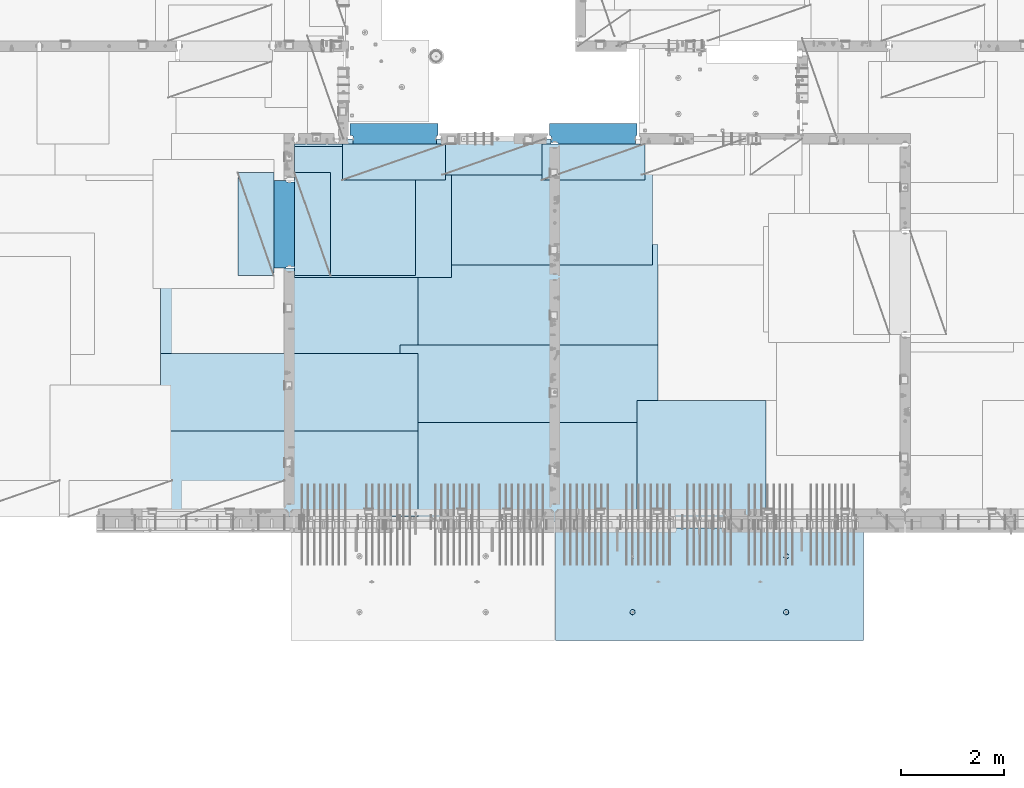
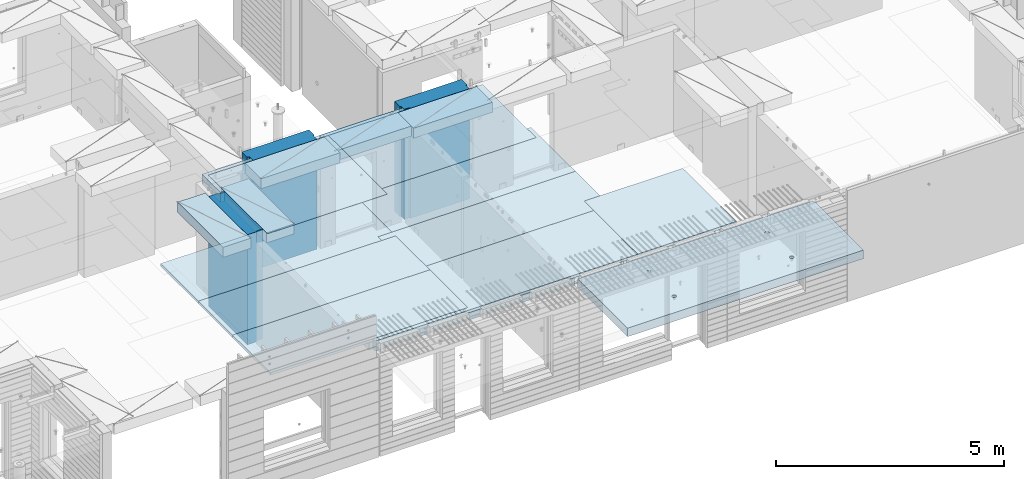
# One storey, part 174 of 309: 18 plates, 2 slabs, 19 elements without a shape of their own.
"""IFC2X3 building model written with IfcOpenShell, lengths in millimetres."""

from ifc_helpers import new_model, si_unit, frame, origin_with_axes, place, context, subcontext, project, spatial, faceted_brep, material, type_object, element, aggregate, save


model = new_model("IFC2X3")

# Units and contexts
model_context = context("Model", 3, precision=1e-05, world=origin_with_axes())
body_context = subcontext(model_context, "Body", "Model", "MODEL_VIEW")
ifc_project = project(units=[si_unit("LENGTHUNIT", "METRE", prefix="MILLI"), si_unit("AREAUNIT", "SQUARE_METRE"), si_unit("VOLUMEUNIT", "CUBIC_METRE"), si_unit("MASSUNIT", "GRAM", prefix="KILO"), si_unit("TIMEUNIT", "SECOND"), si_unit("PLANEANGLEUNIT", "RADIAN"), si_unit("SOLIDANGLEUNIT", "STERADIAN"), si_unit("THERMODYNAMICTEMPERATUREUNIT", "DEGREE_CELSIUS"), si_unit("LUMINOUSINTENSITYUNIT", "LUMEN")], contexts=[model_context])

# Site, building, storey
site_placement = place(None, origin_with_axes())
site = spatial("IfcSite", under=ifc_project, at=site_placement, CompositionType="ELEMENT")
building_placement = place(site_placement, origin_with_axes())
building = spatial("IfcBuilding", under=site, at=building_placement, CompositionType="ELEMENT")
storey_placement = place(building_placement, origin_with_axes())
storey = spatial("IfcBuildingStorey", under=building, at=storey_placement, Name="7", CompositionType="ELEMENT", Elevation=0.0)

# Assembly, plate
assembly_1_placement = place(storey_placement, origin_with_axes())
assembly_1 = element("IfcElementAssembly", 1, at=assembly_1_placement, inside=storey, Name="Steel Assembly", AssemblyPlace="NOTDEFINED", PredefinedType="NOTDEFINED")
ifc_material_1 = material()
plate_type_1 = type_object("IfcPlateType", PredefinedType="NOTDEFINED")
plate_1_placement = place(assembly_1_placement, frame((25910.0, 7750.0, 102695.1), z_axis=(-1.0, 3.00000001838171e-08, 0.0), x_axis=(0.0, 1.0, 0.0)))
plate_1 = element("IfcPlate", 2, at=plate_1_placement, type_object=plate_type_1, material=ifc_material_1, Name="1/2", context=body_context, shape_type="Brep", body=[
    faceted_brep([(0.0, -35.0, 0.0), (0.0, -35.0, 2500.0), (0.0, 35.0, 2500.0), (0.0, 35.0, 0.0), (2349.99951171875, -35.0, 2500.0), (2349.99951171875, 35.0, 2500.0), (2350.0, -35.0, 0.0), (2350.0, 35.0, 0.0)], [[[0, 1, 2, 3]], [[1, 4, 5, 2]], [[4, 6, 7, 5]], [[6, 0, 3, 7]], [[5, 7, 3, 2]], [[6, 4, 1, 0]]]),
])
aggregate(assembly_1, [plate_1])

assembly_2_placement = place(storey_placement, origin_with_axes())
assembly_2 = element("IfcElementAssembly", 3, at=assembly_2_placement, inside=storey, Name="Steel Assembly", AssemblyPlace="NOTDEFINED", PredefinedType="NOTDEFINED")
plate_2_placement = place(assembly_2_placement, frame((16759.9995320312, 12530.0000289158, 102695.1), z_axis=(0.0, 1.0, 0.0), x_axis=(1.0, 0.0, 0.0)))
plate_2 = element("IfcPlate", 4, at=plate_2_placement, type_object=plate_type_1, material=ifc_material_1, Name="1/2", context=body_context, shape_type="Brep", body=[
    faceted_brep([(0.0, -35.0, 0.0), (0.0, -35.0, 2500.0), (0.0, 35.0, 2500.0), (0.0, 35.0, 0.0), (2349.99951171875, -35.0, 2500.0), (2349.99951171875, 35.0, 2500.0), (2350.0, -35.0, 0.0), (2350.0, 35.0, 0.0)], [[[0, 1, 2, 3]], [[1, 4, 5, 2]], [[4, 6, 7, 5]], [[6, 0, 3, 7]], [[5, 7, 3, 2]], [[6, 4, 1, 0]]]),
])
aggregate(assembly_2, [plate_2])

assembly_3_placement = place(storey_placement, origin_with_axes())
assembly_3 = element("IfcElementAssembly", 5, at=assembly_3_placement, inside=storey, Name="Steel Assembly", AssemblyPlace="NOTDEFINED", PredefinedType="NOTDEFINED")
plate_3_placement = place(assembly_3_placement, frame((23810.0, 10780.0, 102695.1), z_axis=(-1.0, 3.00000001838171e-08, 0.0), x_axis=(0.0, 1.0, 0.0)))
plate_3 = element("IfcPlate", 6, at=plate_3_placement, type_object=plate_type_1, material=ifc_material_1, context=body_context, shape_type="Brep", body=[
    faceted_brep([(0.0, -35.0, 0.0), (0.0, -35.0, 5000.0), (0.0, 35.0, 5000.0), (0.0, 35.0, 0.0), (2349.99951171875, -35.0, 5000.0), (2349.99951171875, 35.0, 5000.0), (2350.0, -35.0, 0.0), (2350.0, 35.0, 0.0)], [[[0, 1, 2, 3]], [[1, 4, 5, 2]], [[4, 6, 7, 5]], [[6, 0, 3, 7]], [[5, 7, 3, 2]], [[6, 4, 1, 0]]]),
])
aggregate(assembly_3, [plate_3])

assembly_4_placement = place(storey_placement, origin_with_axes())
assembly_4 = element("IfcElementAssembly", 7, at=assembly_4_placement, inside=storey, Name="Steel Assembly", AssemblyPlace="NOTDEFINED", PredefinedType="NOTDEFINED")
plate_4_placement = place(assembly_4_placement, frame((23710.0, 12730.0, 102695.1), z_axis=(-1.0, 3.00000001838171e-08, 0.0), x_axis=(0.0, 1.0, 0.0)))
plate_4 = element("IfcPlate", 8, at=plate_4_placement, type_object=plate_type_1, material=ifc_material_1, context=body_context, shape_type="Brep", body=[
    faceted_brep([(0.0, -35.0, 0.0), (0.0, -35.0, 5000.0), (0.0, 35.0, 5000.0), (0.0, 35.0, 0.0), (2349.99951171875, -35.0, 5000.0), (2349.99951171875, 35.0, 5000.0), (2350.0, -35.0, 0.0), (2350.0, 35.0, 0.0)], [[[0, 1, 2, 3]], [[1, 4, 5, 2]], [[4, 6, 7, 5]], [[6, 0, 3, 7]], [[5, 7, 3, 2]], [[6, 4, 1, 0]]]),
])
aggregate(assembly_4, [plate_4])

assembly_5_placement = place(storey_placement, origin_with_axes())
assembly_5 = element("IfcElementAssembly", 9, at=assembly_5_placement, inside=storey, Name="Steel Assembly", AssemblyPlace="NOTDEFINED", PredefinedType="NOTDEFINED")
plate_5_placement = place(assembly_5_placement, frame((23810.0, 7750.0, 102695.1), z_axis=(-1.0, 3.00000001838171e-08, 0.0), x_axis=(0.0, 1.0, 0.0)))
plate_5 = element("IfcPlate", 10, at=plate_5_placement, type_object=plate_type_1, material=ifc_material_1, context=body_context, shape_type="Brep", body=[
    faceted_brep([(0.0, -35.0, 0.0), (0.0, -35.0, 5000.0), (0.0, 35.0, 5000.0), (0.0, 35.0, 0.0), (2349.99951171875, -35.0, 5000.0), (2349.99951171875, 35.0, 5000.0), (2350.0, -35.0, 0.0), (2350.0, 35.0, 0.0)], [[[0, 1, 2, 3]], [[1, 4, 5, 2]], [[4, 6, 7, 5]], [[6, 0, 3, 7]], [[5, 7, 3, 2]], [[6, 4, 1, 0]]]),
])
aggregate(assembly_5, [plate_5])

assembly_6_placement = place(storey_placement, origin_with_axes())
assembly_6 = element("IfcElementAssembly", 11, at=assembly_6_placement, inside=storey, Name="Steel Assembly", AssemblyPlace="NOTDEFINED", PredefinedType="NOTDEFINED")
plate_6_placement = place(assembly_6_placement, frame((19160.0, 10325.0, 102695.1), z_axis=(-1.0, 3.00000001838171e-08, 0.0), x_axis=(0.0, 1.0, 0.0)))
plate_6 = element("IfcPlate", 12, at=plate_6_placement, type_object=plate_type_1, material=ifc_material_1, context=body_context, shape_type="Brep", body=[
    faceted_brep([(0.0, -35.0, 0.0), (0.0, -35.0, 5000.0), (0.0, 35.0, 5000.0), (0.0, 35.0, 0.0), (2349.99951171875, -35.0, 5000.0), (2349.99951171875, 35.0, 5000.0), (2350.0, -35.0, 0.0), (2350.0, 35.0, 0.0)], [[[0, 1, 2, 3]], [[1, 4, 5, 2]], [[4, 6, 7, 5]], [[6, 0, 3, 7]], [[5, 7, 3, 2]], [[6, 4, 1, 0]]]),
])
aggregate(assembly_6, [plate_6])

assembly_7_placement = place(storey_placement, origin_with_axes())
assembly_7 = element("IfcElementAssembly", 13, at=assembly_7_placement, inside=storey, Name="Steel Assembly", AssemblyPlace="NOTDEFINED", PredefinedType="NOTDEFINED")
plate_7_placement = place(assembly_7_placement, frame((19160.0, 7850.0, 102695.1), z_axis=(-1.0, 3.00000001838171e-08, 0.0), x_axis=(0.0, 1.0, 0.0)))
plate_7 = element("IfcPlate", 14, at=plate_7_placement, type_object=plate_type_1, material=ifc_material_1, context=body_context, shape_type="Brep", body=[
    faceted_brep([(0.0, -35.0, 0.0), (0.0, -35.0, 5000.0), (0.0, 35.0, 5000.0), (0.0, 35.0, 0.0), (2349.99951171875, -35.0, 5000.0), (2349.99951171875, 35.0, 5000.0), (2350.0, -35.0, 0.0), (2350.0, 35.0, 0.0)], [[[0, 1, 2, 3]], [[1, 4, 5, 2]], [[4, 6, 7, 5]], [[6, 0, 3, 7]], [[5, 7, 3, 2]], [[6, 4, 1, 0]]]),
])
aggregate(assembly_7, [plate_7])

assembly_8_placement = place(storey_placement, origin_with_axes())
assembly_8 = element("IfcElementAssembly", 15, at=assembly_8_placement, inside=storey, Name="Steel Assembly", AssemblyPlace="NOTDEFINED", PredefinedType="NOTDEFINED")
plate_type_2 = type_object("IfcPlateType", PredefinedType="NOTDEFINED")
plate_8_placement = place(assembly_8_placement, frame((18810.0, 11180.0000122641, 102695.100000381), z_axis=(1.0, 0.0, 0.0), x_axis=(0.0, -1.0, 0.0)))
plate_8 = element("IfcPlate", 16, at=plate_8_placement, type_object=plate_type_2, material=ifc_material_1, context=body_context, shape_type="Brep", body=[
    faceted_brep([(0.0, -35.0, 0.0), (0.0, -35.0, 5000.0), (0.0, 35.0, 5000.0), (0.0, 35.0, 0.0), (1499.99951171875, -35.0, 5000.0), (1499.99951171875, 35.0, 5000.0), (1500.0, -35.0, 0.0), (1500.0, 35.0, 0.0)], [[[0, 1, 2, 3]], [[1, 4, 5, 2]], [[4, 6, 7, 5]], [[6, 0, 3, 7]], [[5, 7, 3, 2]], [[6, 4, 1, 0]]]),
])
aggregate(assembly_8, [plate_8])

assembly_9_placement = place(storey_placement, origin_with_axes())
assembly_9 = element("IfcElementAssembly", 17, at=assembly_9_placement, inside=storey, Name="Steel Assembly", AssemblyPlace="NOTDEFINED", PredefinedType="NOTDEFINED")
plate_9_placement = place(assembly_9_placement, frame((14160.0, 11015.0000122641, 102695.100000381), z_axis=(1.0, 0.0, 0.0), x_axis=(0.0, -1.0, 0.0)))
plate_9 = element("IfcPlate", 18, at=plate_9_placement, type_object=plate_type_2, material=ifc_material_1, context=body_context, shape_type="Brep", body=[
    faceted_brep([(0.0, -35.0, 0.0), (0.0, -35.0, 5000.0), (0.0, 35.0, 5000.0), (0.0, 35.0, 0.0), (1499.99951171875, -35.0, 5000.0), (1499.99951171875, 35.0, 5000.0), (1500.0, -35.0, 0.0), (1500.0, 35.0, 0.0)], [[[0, 1, 2, 3]], [[1, 4, 5, 2]], [[4, 6, 7, 5]], [[6, 0, 3, 7]], [[5, 7, 3, 2]], [[6, 4, 1, 0]]]),
])
aggregate(assembly_9, [plate_9])

assembly_10_placement = place(storey_placement, origin_with_axes())
assembly_10 = element("IfcElementAssembly", 19, at=assembly_10_placement, inside=storey, Name="Steel Assembly", AssemblyPlace="NOTDEFINED", PredefinedType="NOTDEFINED")
plate_type_3 = type_object("IfcPlateType", PredefinedType="NOTDEFINED")
plate_10_placement = place(assembly_10_placement, frame((16759.9998779297, 14525.0, 102595.3), z_axis=(1.0, 0.0, 0.0), x_axis=(0.0, -1.0, 0.0)))
plate_10 = element("IfcPlate", 20, at=plate_10_placement, type_object=plate_type_3, material=ifc_material_1, Name="RE1", context=body_context, shape_type="Brep", body=[
    faceted_brep([(1.81898940354586e-12, -135.0, 1.81898940354586e-12), (0.0, -135.0, 699.999999999996), (0.0, 135.0, 699.999999999996), (1.81898940354586e-12, 135.0, 1.81898940354586e-12), (1999.99951171875, -135.0, 699.999999999993), (1999.99951171875, 135.0, 699.999999999993), (2000.0, -135.0, -3.63797880709171e-12), (2000.0, 135.0, -3.63797880709171e-12)], [[[0, 1, 2, 3]], [[1, 4, 5, 2]], [[4, 6, 7, 5]], [[6, 0, 3, 7]], [[5, 7, 3, 2]], [[6, 4, 1, 0]]]),
])
aggregate(assembly_10, [plate_10])

assembly_11_placement = place(storey_placement, origin_with_axes())
assembly_11 = element("IfcElementAssembly", 21, at=assembly_11_placement, inside=storey, Name="Steel Assembly", AssemblyPlace="NOTDEFINED", PredefinedType="NOTDEFINED")
plate_11_placement = place(assembly_11_placement, frame((16359.7701220703, 12525.0, 102595.3), z_axis=(-1.0, 3.00000001838171e-08, 0.0), x_axis=(0.0, 1.0, 0.0)))
plate_11 = element("IfcPlate", 22, at=plate_11_placement, type_object=plate_type_3, material=ifc_material_1, Name="RE1", context=body_context, shape_type="Brep", body=[
    faceted_brep([(1.81898940354586e-12, -135.0, 1.81898940354586e-12), (0.0, -135.0, 699.999999999996), (0.0, 135.0, 699.999999999996), (1.81898940354586e-12, 135.0, 1.81898940354586e-12), (1999.99951171875, -135.0, 699.999999999993), (1999.99951171875, 135.0, 699.999999999993), (2000.0, -135.0, -3.63797880709171e-12), (2000.0, 135.0, -3.63797880709171e-12)], [[[0, 1, 2, 3]], [[1, 4, 5, 2]], [[4, 6, 7, 5]], [[6, 0, 3, 7]], [[5, 7, 3, 2]], [[6, 4, 1, 0]]]),
])
aggregate(assembly_11, [plate_11])

assembly_12_placement = place(storey_placement, origin_with_axes())
assembly_12 = element("IfcElementAssembly", 23, at=assembly_12_placement, inside=storey, Name="Steel Assembly", AssemblyPlace="NOTDEFINED", PredefinedType="NOTDEFINED")
plate_12_placement = place(assembly_12_placement, frame((21624.9991457614, 15179.9998963664, 102595.3), z_axis=(0.0, -1.0, 0.0), x_axis=(-1.0, 3.00000001838171e-08, 0.0)))
plate_12 = element("IfcPlate", 24, at=plate_12_placement, type_object=plate_type_3, material=ifc_material_1, Name="RE1", context=body_context, shape_type="Brep", body=[
    faceted_brep([(1.81898940354586e-12, -135.0, 1.81898940354586e-12), (0.0, -135.0, 699.999999999996), (0.0, 135.0, 699.999999999996), (1.81898940354586e-12, 135.0, 1.81898940354586e-12), (1999.99951171875, -135.0, 699.999999999993), (1999.99951171875, 135.0, 699.999999999993), (2000.0, -135.0, -3.63797880709171e-12), (2000.0, 135.0, -3.63797880709171e-12)], [[[0, 1, 2, 3]], [[1, 4, 5, 2]], [[4, 6, 7, 5]], [[6, 0, 3, 7]], [[5, 7, 3, 2]], [[6, 4, 1, 0]]]),
])
aggregate(assembly_12, [plate_12])

assembly_13_placement = place(storey_placement, origin_with_axes())
assembly_13 = element("IfcElementAssembly", 25, at=assembly_13_placement, inside=storey, Name="Steel Assembly", AssemblyPlace="NOTDEFINED", PredefinedType="NOTDEFINED")
plate_13_placement = place(assembly_13_placement, frame((23559.9991457614, 15079.9998963664, 102595.3), z_axis=(0.0, -1.0, 0.0), x_axis=(-1.0, 3.00000001838171e-08, 0.0)))
plate_13 = element("IfcPlate", 26, at=plate_13_placement, type_object=plate_type_3, material=ifc_material_1, Name="RE1", context=body_context, shape_type="Brep", body=[
    faceted_brep([(1.81898940354586e-12, -135.0, 1.81898940354586e-12), (0.0, -135.0, 699.999999999996), (0.0, 135.0, 699.999999999996), (1.81898940354586e-12, 135.0, 1.81898940354586e-12), (1999.99951171875, -135.0, 699.999999999993), (1999.99951171875, 135.0, 699.999999999993), (2000.0, -135.0, -3.63797880709171e-12), (2000.0, 135.0, -3.63797880709171e-12)], [[[0, 1, 2, 3]], [[1, 4, 5, 2]], [[4, 6, 7, 5]], [[6, 0, 3, 7]], [[5, 7, 3, 2]], [[6, 4, 1, 0]]]),
])
aggregate(assembly_13, [plate_13])

assembly_14_placement = place(storey_placement, origin_with_axes())
assembly_14 = element("IfcElementAssembly", 27, at=assembly_14_placement, inside=storey, Name="Steel Assembly", AssemblyPlace="NOTDEFINED", PredefinedType="NOTDEFINED")
plate_14_placement = place(assembly_14_placement, frame((19689.9991457614, 15079.9998963664, 102595.3), z_axis=(0.0, -1.0, 0.0), x_axis=(-1.0, 3.00000001838171e-08, 0.0)))
plate_14 = element("IfcPlate", 28, at=plate_14_placement, type_object=plate_type_3, material=ifc_material_1, Name="RE1", context=body_context, shape_type="Brep", body=[
    faceted_brep([(1.81898940354586e-12, -135.0, 1.81898940354586e-12), (0.0, -135.0, 699.999999999996), (0.0, 135.0, 699.999999999996), (1.81898940354586e-12, 135.0, 1.81898940354586e-12), (1999.99951171875, -135.0, 699.999999999993), (1999.99951171875, 135.0, 699.999999999993), (2000.0, -135.0, -3.63797880709171e-12), (2000.0, 135.0, -3.63797880709171e-12)], [[[0, 1, 2, 3]], [[1, 4, 5, 2]], [[4, 6, 7, 5]], [[6, 0, 3, 7]], [[5, 7, 3, 2]], [[6, 4, 1, 0]]]),
])
aggregate(assembly_14, [plate_14])

# Assembly, plate, slab
assembly_15_placement = place(storey_placement, origin_with_axes())
assembly_15 = element("IfcElementAssembly", 29, at=assembly_15_placement, inside=storey, AssemblyPlace="NOTDEFINED", PredefinedType="REINFORCEMENT_UNIT")
plate_type_4 = type_object("IfcPlateType", PredefinedType="NOTDEFINED")
plate_15_placement = place(assembly_15_placement, frame((16760.0002457424, 12487.9997681111, 102725.45), z_axis=(0.0, 1.0, 0.0), x_axis=(1.0, 0.0, 0.0)))
plate_15 = element("IfcPlate", 30, at=plate_15_placement, type_object=plate_type_4, material=ifc_material_1, context=body_context, shape_type="Brep", body=[
    faceted_brep([(0.0, -5.0, 0.0), (0.0, -5.0, 2592.0), (0.0, 5.0, 2592.0), (0.0, 5.0, 0.0), (3041.99975585938, -5.0, 2592.0), (3041.99975585938, 5.0, 2592.0), (3041.99975585938, -5.0, 0.0), (3041.99975585938, 5.0, 0.0)], [[[0, 1, 2, 3]], [[1, 4, 5, 2]], [[4, 6, 7, 5]], [[6, 0, 3, 7]], [[5, 7, 3, 2]], [[6, 4, 1, 0]]]),
])
ifc_material_2 = material(Name="CONCRETE/C30/37")
slab_type_1 = type_object("IfcSlabType", PredefinedType="NOTDEFINED")
slab_1_placement = place(assembly_15_placement, frame((21810.0, 15180.0, 102595.0), z_axis=(0.0, -1.0, 0.0), x_axis=(-1.0, 3.00000001838171e-08, 0.0)))
slab_1 = element("IfcSlab", 31, at=slab_1_placement, type_object=slab_type_1, material=ifc_material_2, PredefinedType="FLOOR", context=body_context, shape_type="Brep", body=[
    faceted_brep([(2300.00087620694, -135.0, -2.78342304227408e-06), (2300.00087620694, 135.0, 0.0), (2300.00087620694, 135.0, 100.000233727807), (2300.00087620694, -135.0, 100.000233727807), (3920.000509996, 135.000000000015, 100.000233727807), (3920.000509996, -135.0, 100.000233727807), (3920.00085449219, -135.0, 0.0), (3920.00085449219, 135.0, 0.0), (5150.0, 135.0, 0.0), (5150.0, -135.0, 0.0), (5150.0, 135.0, 804.999923541527), (5150.0, -135.0, 804.999923541527), (5049.99975425761, 135.0, 804.999923541527), (5049.99975425761, -135.0, 804.999923541527), (5049.99975425761, 135.0, 2504.99992354153), (5049.99975425761, -135.0, 2504.99992354153), (5150.0, 135.0, 2504.99992354153), (5150.0, -135.0, 2504.99992354153), (5150.0, 135.0, 7330.0), (5150.0, -135.0, 7330.0), (5055.0, -135.0, 7330.0), (5055.0, 135.0, 7330.0), (5055.0, -135.0, 7430.0), (5055.0, 135.0, 7430.0), (0.0, -135.0, 7430.0), (0.0, 135.0, 7430.0), (70.0000000000036, -135.0, -8.47121555125341e-08), (3.63797880709171e-12, -135.0, 100.0), (70.0000000000036, -135.000000000015, 100.0), (70.0000000000036, 135.0, 0.0), (70.0000000000036, 135.0, 100.0), (0.0, 135.0, 100.0)], [[[0, 1, 2, 3]], [[3, 2, 4, 5]], [[6, 5, 4, 7]], [[8, 9, 6, 7]], [[9, 8, 10, 11]], [[11, 10, 12, 13]], [[13, 12, 14, 15]], [[15, 14, 16, 17]], [[18, 19, 17, 16]], [[20, 19, 18, 21]], [[22, 20, 21, 23]], [[24, 22, 23, 25]], [[26, 0, 3, 5, 6, 9, 11, 13, 15, 17, 19, 20, 22, 24, 27, 28]], [[1, 0, 26, 29]], [[25, 23, 21, 18, 16, 14, 12, 10, 8, 7, 4, 2, 1, 29, 30, 31]], [[26, 28, 30, 29]], [[27, 31, 30, 28]], [[24, 25, 31, 27]]]),
])
aggregate(assembly_15, [plate_15, slab_1])

# Assembly, plate
assembly_16_placement = place(storey_placement, origin_with_axes())
assembly_16 = element("IfcElementAssembly", 32, at=assembly_16_placement, inside=storey, Name="Steel Assembly", AssemblyPlace="NOTDEFINED", PredefinedType="NOTDEFINED")
ifc_material_3 = material()
plate_type_5 = type_object("IfcPlateType", PredefinedType="NOTDEFINED")
plate_16_placement = place(assembly_16_placement, frame((17840.0, 15080.0, 101255.600000381), z_axis=(0.0, 1.0, 0.0), x_axis=(1.0, 0.0, 0.0)))
plate_16 = element("IfcPlate", 33, at=plate_16_placement, type_object=plate_type_5, material=ifc_material_3, context=body_context, shape_type="Brep", body=[
    faceted_brep([(49.9991463160914, -1475.0, 156.999999814216), (49.9991455078125, -1216.89999961853, 156.999999999998), (49.9994900039455, -1216.89999961853, -0.000233727812883444), (49.9994832763732, -1475.0, 0.0), (0.0, -1475.0, 170.000000230655), (-0.00085392879191204, -1216.89999961853, 170.000000368096), (0.0, -1475.0, 400.0), (1699.99914550781, -1475.0, 400.0), (1699.99914550781, 1475.0, 400.0), (0.0, 1475.0, 400.0), (1699.99914550781, -1475.0, 169.999999999998), (1699.99914550781, 1475.0, 169.999999999998), (1669.99914550781, 1475.0, 156.999999999998), (1669.99914550781, 1475.0, 3.63797880709171e-12), (49.9994900039455, 1475.0, 0.0), (49.9991455078125, 1475.0, 156.999999999998), (0.0, 1475.0, 170.000000368096), (1669.99914550781, -1475.0, 156.999999999998), (1669.99914550781, -1475.0, 3.63797880709171e-12)], [[[0, 1, 2, 3]], [[4, 5, 1, 0]], [[6, 7, 8, 9]], [[8, 7, 10, 11]], [[9, 8, 11, 12, 13, 14, 15, 16]], [[10, 17, 12, 11]], [[18, 13, 12, 17]], [[14, 13, 18, 3, 2]], [[14, 2, 1, 15]], [[15, 1, 5, 16]], [[6, 9, 16, 5, 4]], [[18, 17, 10, 7, 6, 4, 0, 3]]]),
])
aggregate(assembly_16, [plate_16])

assembly_17_placement = place(storey_placement, origin_with_axes())
assembly_17 = element("IfcElementAssembly", 34, at=assembly_17_placement, inside=storey, Name="Steel Assembly", AssemblyPlace="NOTDEFINED", PredefinedType="NOTDEFINED")
plate_17_placement = place(assembly_17_placement, frame((21710.0, 15080.0, 101255.600000381), z_axis=(0.0, 1.0, 0.0), x_axis=(1.0, 0.0, 0.0)))
plate_17 = element("IfcPlate", 35, at=plate_17_placement, type_object=plate_type_5, material=ifc_material_3, context=body_context, shape_type="Brep", body=[
    faceted_brep([(30.0, -1475.0, 29.9998239177003), (30.0, 1475.0, 29.9998239177003), (157.0, 1475.0, 29.9998239177003), (157.0, -1475.0, 29.9998239177003), (169.999923697669, -1475.0, 0.0), (169.999923697669, 1475.0, 0.0), (0.0, -1475.0, 170.000000230655), (0.0, 1475.0, 170.000000368096), (30.0, 1475.0, 156.999999999998), (30.0, -1475.0, 156.999999999998), (0.0, -1475.0, 400.0), (0.0, 1475.0, 400.0), (1699.99914550781, -1475.0, 400.0), (1699.99914550781, 1475.0, 400.0), (1699.99914550781, -1475.0, 169.999999999998), (1699.99914550781, 1475.0, 169.999999999998), (1669.99914550781, -1475.0, 156.999999999998), (1669.99914550781, 1475.0, 156.999999999998), (1669.99914550781, -1475.0, 3.63797880709171e-12), (1669.99914550781, 1475.0, 3.63797880709171e-12)], [[[0, 1, 2, 3]], [[4, 3, 2, 5]], [[6, 7, 8, 9]], [[10, 11, 7, 6]], [[10, 12, 13, 11]], [[13, 12, 14, 15]], [[14, 16, 17, 15]], [[18, 19, 17, 16]], [[19, 18, 4, 5]], [[1, 8, 7, 11, 13, 15, 17, 19, 5, 2]], [[9, 8, 1, 0]], [[18, 16, 14, 12, 10, 6, 9, 0, 3, 4]]]),
])
aggregate(assembly_17, [plate_17])

assembly_18_placement = place(storey_placement, origin_with_axes())
assembly_18 = element("IfcElementAssembly", 36, at=assembly_18_placement, inside=storey, Name="Steel Assembly", AssemblyPlace="NOTDEFINED", PredefinedType="NOTDEFINED")
plate_18_placement = place(assembly_18_placement, frame((16760.0, 12675.0, 101255.600000381), z_axis=(-0.999999990476206, -0.000138013000065496, 0.0), x_axis=(-0.000138013000066464, 0.999999990476206, 0.0)))
plate_18 = element("IfcPlate", 37, at=plate_18_placement, type_object=plate_type_5, material=ifc_material_3, context=body_context, shape_type="Brep", body=[
    faceted_brep([(0.0234607562470046, -1475.0, 169.989834633274), (0.0234607562470046, 1475.0, 169.989834633274), (30.0, 1475.0, 156.999999999998), (30.0, -1475.0, 156.999999999998), (29.9999998430139, -1475.0, 0.0), (29.9999998430139, 1475.0, 0.0), (0.0552374608814716, -1475.0, 400.234619140623), (1700.05529785156, -1475.0, 399.999999999998), (1700.05529785156, 1475.0, 399.999999999998), (0.0552374608814716, 1475.0, 400.234619140623), (1700.0235408123, -1475.0, 169.775517151291), (1700.0235408123, 1475.0, 169.775517151291), (1670.00014467176, -1475.0, 156.765378823566), (1670.00014467176, 1475.0, 156.765378823566), (1670.00014467148, -1475.0, 1.13504938781261e-09), (1670.00014467148, 1475.0, 1.13504938781261e-09)], [[[0, 1, 2, 3]], [[4, 3, 2, 5]], [[6, 7, 8, 9]], [[8, 7, 10, 11]], [[12, 13, 11, 10]], [[14, 15, 13, 12]], [[15, 14, 4, 5]], [[1, 9, 8, 11, 13, 15, 5, 2]], [[6, 9, 1, 0]], [[14, 12, 10, 7, 6, 0, 3, 4]]]),
])
aggregate(assembly_18, [plate_18])

# Assembly, slab
assembly_19_placement = place(storey_placement, origin_with_axes())
assembly_19 = element("IfcElementAssembly", 38, at=assembly_19_placement, inside=storey, AssemblyPlace="NOTDEFINED", PredefinedType="REINFORCEMENT_UNIT")
ifc_material_4 = material(Name="CONCRETE/C35/45")
slab_type_2 = type_object("IfcSlabType", PredefinedType="NOTDEFINED")
slab_2_placement = place(assembly_19_placement, frame((27799.9998568133, 7629.99655735226, 102585.0), z_axis=(-1.11800000013248e-06, -0.999999999999375, 0.0), x_axis=(-0.999999999999093, 1.34699999998405e-06, 0.0)))
slab_2 = element("IfcSlab", 39, at=slab_2_placement, type_object=slab_type_2, material=ifc_material_4, PredefinedType="FLOOR", context=body_context, shape_type="Brep", body=[
    faceted_brep([(5920.00056237947, 114.999716763676, 2129.99513802927), (5920.00056911834, 104.999716832332, 2124.99513805801), (60.0005693744861, 104.97210543578, 2125.04246289596), (60.0005626356178, 114.972105367109, 2130.04246286721), (5920.00048162034, 114.999715914935, 2119.99513532379), (60.0004818764901, 114.972104518369, 2120.04246016174), (1515.44902267693, -100.000000047556, 1587.44800295366), (1529.38742739841, -100.000000040454, 1594.54999509277), (1540.44900177064, -100.000000029395, 1605.61159492878), (1547.55096182354, -100.000000015454, 1619.55001599902), (1549.99811822485, -100.0, 1635.00086853445), (1547.55092625568, -99.9999999845459, 1650.45171543649), (1540.44893411656, -99.9999999706051, 1664.39012015799), (1529.38733428056, -99.9999999595457, 1675.45169453022), (1515.44891321032, -99.9999999524443, 1682.55365458311), (1499.99806067488, -99.9999999499996, 1685.00081098442), (1484.54721377284, -99.9999999524443, 1682.55361901525), (1470.60880905135, -99.9999999595457, 1675.45162687613), (1459.54723467912, -99.9999999706051, 1664.39002704013), (1452.44527462623, -99.9999999845459, 1650.45160596989), (1449.99811822491, -100.0, 1635.00075343445), (1452.44531019409, -100.000000015454, 1619.54990653241), (1459.5473023332, -100.000000029395, 1605.61150181092), (1470.60890216921, -100.000000040454, 1594.54992743869), (1484.54732323945, -100.000000047556, 1587.4479673858), (1499.99817577488, -100.00000005, 1585.00081098449), (1450.82419174022, -115.0, 1619.02317116893), (1448.29357277037, -115.0, 1635.00075148752), (1458.16829724878, -115.0, 1604.60959356067), (1469.60699707919, -115.0, 1593.17092006393), (1484.02059159394, -115.0, 1585.82684773798), (1499.99817773681, -115.0, 1583.29626555082), (1515.97575805424, -115.0, 1585.82688451837), (1530.3893356629, -115.0, 1593.1709900244), (1541.82800916145, -115.0, 1604.609689853), (1549.17208148994, -115.0, 1619.02328436735), (1551.70266367939, -115.0, 1635.00087051139), (1549.172044713, -115.0, 1650.9784508311), (1541.82793920657, -115.0, 1665.3920284423), (1530.38923937616, -115.0, 1676.83070194267), (1515.97564485927, -115.0, 1684.17477427156), (1499.99805871295, -115.0, 1686.70535645984), (1484.02047839207, -115.0, 1684.17473749116), (1469.60690078128, -115.0, 1676.8306319822), (1458.16822728272, -115.0, 1665.39193214997), (1450.82415495636, -115.0, 1650.97833763268), (1515.45027151193, -109.000000047556, 502.448002954375), (1529.38867623342, -109.000000040454, 509.549995093494), (1540.45025060565, -109.000000029395, 520.611594929497), (1547.55221065854, -109.000000015454, 534.550015999738), (1549.99936705985, -109.0, 550.000868535172), (1547.55217509068, -108.999999984546, 565.451715437212), (1540.45018295156, -108.999999970605, 579.390120158705), (1529.38858311556, -108.999999959546, 590.451694530934), (1515.45016204532, -108.999999952444, 597.553654583828), (1499.99930950988, -108.99999995, 600.00081098514), (1484.54846260784, -108.999999952444, 597.553619015972), (1470.61005788635, -108.999999959546, 590.451626876852), (1459.54848351412, -108.999999970605, 579.390027040849), (1452.44652346123, -108.999999984546, 565.451605970607), (1449.99936705991, -109.0, 550.000753435173), (1452.44655902909, -109.000000015454, 534.549906533133), (1459.5485511682, -109.000000029395, 520.611501811641), (1470.61015100421, -109.000000040454, 509.549927439411), (1484.54857207445, -109.000000047556, 502.447967386519), (1499.99942460988, -109.00000005, 500.000810985206), (1451.79811164854, -115.0, 534.339212388066), (1449.3175488781, -115.0, 550.0007526564), (1458.99694913606, -115.0, 520.210738512719), (1470.20938896982, -115.0, 508.998324491739), (1484.33787941725, -115.0, 501.799519530473), (1499.99942539465, -115.0, 499.318992815147), (1515.66096566185, -115.0, 501.799555583345), (1529.78943953759, -115.0, 508.998393068377), (1541.00185356035, -115.0, 520.210832900364), (1548.2006585241, -115.0, 534.339323347397), (1550.68118524167, -115.0, 550.000869325945), (1548.20062247461, -115.0, 565.662409595381), (1541.00178498919, -115.0, 579.790883473606), (1529.78934515542, -115.0, 591.003297498146), (1515.66085470591, -115.0, 598.20210246229), (1499.99930872511, -115.0, 600.682629178717), (1484.33776845453, -115.0, 598.202066409418), (1470.2092945767, -115.0, 591.003228921508), (1458.99688055394, -115.0, 579.790789085961), (1451.79807559228, -115.0, 565.66229863605), (4495.44902267495, -100.000000047556, 1587.45143293366), (4509.38742739644, -100.000000040454, 1594.55342507277), (4520.44900176867, -100.000000029395, 1605.61502490878), (4527.55096182156, -100.000000015454, 1619.55344597902), (4529.99811822288, -100.0, 1635.00429851445), (4527.55092625371, -99.9999999845459, 1650.45514541649), (4520.44893411459, -99.9999999706051, 1664.39355013799), (4509.38733427858, -99.9999999595457, 1675.45512451022), (4495.44891320834, -99.9999999524443, 1682.55708456311), (4479.99806067291, -99.9999999499996, 1685.00424096442), (4464.54721377087, -99.9999999524443, 1682.55704899525), (4450.60880904938, -99.9999999595457, 1675.45505685613), (4439.54723467715, -99.9999999706051, 1664.39345702013), (4432.44527462425, -99.9999999845459, 1650.45503594989), (4429.99811822294, -100.0, 1635.00418341445), (4432.44531019211, -100.000000015454, 1619.55333651241), (4439.54730233123, -100.000000029395, 1605.61493179092), (4450.60890216723, -100.000000040454, 1594.55335741869), (4464.54732323748, -100.000000047556, 1587.4513973658), (4479.99817577291, -100.00000005, 1585.00424096449), (4430.82419173824, -115.0, 1619.02660114893), (4428.2935727684, -115.0, 1635.00418146752), (4438.16829724681, -115.0, 1604.61302354067), (4449.60699707722, -115.0, 1593.17435004393), (4464.02059159197, -115.0, 1585.83027771798), (4479.99817773484, -115.0, 1583.29969553082), (4495.97575805227, -115.0, 1585.83031449837), (4510.38933566093, -115.0, 1593.1744200044), (4521.82800915948, -115.0, 1604.613119833), (4529.17208148797, -115.0, 1619.02671434735), (4531.70266367742, -115.0, 1635.00430049139), (4529.17204471103, -115.0, 1650.9818808111), (4521.8279392046, -115.0, 1665.3954584223), (4510.38923937418, -115.0, 1676.83413192267), (4495.9756448573, -115.0, 1684.17820425156), (4479.99805871098, -115.0, 1686.70878643984), (4464.0204783901, -115.0, 1684.17816747116), (4449.6069007793, -115.0, 1676.8340619622), (4438.16822728074, -115.0, 1665.39536212997), (4430.82415495439, -115.0, 1650.98176761268), (4495.45027150995, -109.000000047556, 502.451432934375), (4509.38867623144, -109.000000040454, 509.553425073494), (4520.45025060367, -109.000000029395, 520.615024909497), (4527.55221065656, -109.000000015454, 534.553445979738), (4529.99936705788, -109.0, 550.004298515172), (4527.55217508871, -108.999999984546, 565.455145417212), (4520.45018294959, -108.999999970605, 579.393550138705), (4509.38858311358, -108.999999959546, 590.455124510934), (4495.45016204334, -108.999999952444, 597.557084563828), (4479.99930950791, -108.99999995, 600.00424096514), (4464.54846260587, -108.999999952444, 597.557048995972), (4450.61005788438, -108.999999959546, 590.455056856852), (4439.54848351215, -108.999999970605, 579.393457020848), (4432.44652345925, -108.999999984546, 565.455035950607), (4429.99936705794, -109.0, 550.004183415173), (4432.44655902711, -109.000000015454, 534.553336513133), (4439.54855116623, -109.000000029395, 520.614931791641), (4450.61015100223, -109.000000040454, 509.553357419411), (4464.54857207248, -109.000000047556, 502.451397366519), (4479.99942460791, -109.00000005, 500.004240965206), (4431.79811164657, -115.0, 534.342642368066), (4429.31754887612, -115.0, 550.004182636399), (4438.99694913408, -115.0, 520.214168492719), (4450.20938896785, -115.0, 509.001754471739), (4464.33787941528, -115.0, 501.802949510473), (4479.99942539268, -115.0, 499.322422795147), (4495.66096565988, -115.0, 501.802985563345), (4509.78943953561, -115.0, 509.001823048377), (4521.00185355838, -115.0, 520.214262880364), (4528.20065852212, -115.0, 534.342753327397), (4530.6811852397, -115.0, 550.004299305945), (4528.20062247264, -115.0, 565.665839575381), (4521.00178498722, -115.0, 579.794313453606), (4509.78934515344, -115.0, 591.006727478146), (4495.66085470393, -115.0, 598.20553244229), (4479.99930872314, -115.0, 600.686059158716), (4464.33776845256, -115.0, 598.205496389418), (4450.20929457473, -115.0, 591.006658901508), (4438.99688055196, -115.0, 579.794219065961), (4431.79807559031, -115.0, 565.66572861605), (5980.0, -115.0, -2.4019755073823e-09), (5980.0009765625, -115.0, 2184.99365234375), (0.000660869696730515, -115.0, 2184.99365234375), (7.27595761418343e-12, -115.0, 0.0), (7.27595761418343e-12, 115.0, 0.0), (5980.0, 115.0, -2.4019755073823e-09), (5980.0009765625, 115.0, 2184.99365234375), (0.000660869696730515, 115.0, 2184.99365234375)], [[[0, 1, 2, 3]], [[4, 1, 0]], [[5, 2, 1, 4]], [[3, 2, 5]], [[6, 7, 8, 9, 10, 11, 12, 13, 14, 15, 16, 17, 18, 19, 20, 21, 22, 23, 24, 25]], [[26, 21, 20, 27]], [[28, 22, 21, 26]], [[29, 23, 22, 28]], [[30, 24, 23, 29]], [[31, 25, 24, 30]], [[32, 6, 25, 31]], [[33, 7, 6, 32]], [[34, 8, 7, 33]], [[35, 9, 8, 34]], [[36, 10, 9, 35]], [[37, 11, 10, 36]], [[38, 12, 11, 37]], [[39, 13, 12, 38]], [[40, 14, 13, 39]], [[41, 15, 14, 40]], [[42, 16, 15, 41]], [[43, 17, 16, 42]], [[44, 18, 17, 43]], [[45, 19, 18, 44]], [[27, 20, 19, 45]], [[46, 47, 48, 49, 50, 51, 52, 53, 54, 55, 56, 57, 58, 59, 60, 61, 62, 63, 64, 65]], [[66, 61, 60, 67]], [[68, 62, 61, 66]], [[69, 63, 62, 68]], [[70, 64, 63, 69]], [[71, 65, 64, 70]], [[72, 46, 65, 71]], [[73, 47, 46, 72]], [[74, 48, 47, 73]], [[75, 49, 48, 74]], [[76, 50, 49, 75]], [[77, 51, 50, 76]], [[78, 52, 51, 77]], [[79, 53, 52, 78]], [[80, 54, 53, 79]], [[81, 55, 54, 80]], [[82, 56, 55, 81]], [[83, 57, 56, 82]], [[84, 58, 57, 83]], [[85, 59, 58, 84]], [[67, 60, 59, 85]], [[86, 87, 88, 89, 90, 91, 92, 93, 94, 95, 96, 97, 98, 99, 100, 101, 102, 103, 104, 105]], [[106, 101, 100, 107]], [[108, 102, 101, 106]], [[109, 103, 102, 108]], [[110, 104, 103, 109]], [[111, 105, 104, 110]], [[112, 86, 105, 111]], [[113, 87, 86, 112]], [[114, 88, 87, 113]], [[115, 89, 88, 114]], [[116, 90, 89, 115]], [[117, 91, 90, 116]], [[118, 92, 91, 117]], [[119, 93, 92, 118]], [[120, 94, 93, 119]], [[121, 95, 94, 120]], [[122, 96, 95, 121]], [[123, 97, 96, 122]], [[124, 98, 97, 123]], [[125, 99, 98, 124]], [[107, 100, 99, 125]], [[126, 127, 128, 129, 130, 131, 132, 133, 134, 135, 136, 137, 138, 139, 140, 141, 142, 143, 144, 145]], [[146, 141, 140, 147]], [[148, 142, 141, 146]], [[149, 143, 142, 148]], [[150, 144, 143, 149]], [[151, 145, 144, 150]], [[152, 126, 145, 151]], [[153, 127, 126, 152]], [[154, 128, 127, 153]], [[155, 129, 128, 154]], [[156, 130, 129, 155]], [[157, 131, 130, 156]], [[158, 132, 131, 157]], [[159, 133, 132, 158]], [[160, 134, 133, 159]], [[161, 135, 134, 160]], [[162, 136, 135, 161]], [[163, 137, 136, 162]], [[164, 138, 137, 163]], [[165, 139, 138, 164]], [[147, 140, 139, 165]], [[166, 167, 168, 169], [164, 163, 162, 161, 160, 159, 158, 157, 156, 155, 154, 153, 152, 151, 150, 149, 148, 146, 147, 165], [124, 123, 122, 121, 120, 119, 118, 117, 116, 115, 114, 113, 112, 111, 110, 109, 108, 106, 107, 125], [84, 83, 82, 81, 80, 79, 78, 77, 76, 75, 74, 73, 72, 71, 70, 69, 68, 66, 67, 85], [44, 43, 42, 41, 40, 39, 38, 37, 36, 35, 34, 33, 32, 31, 30, 29, 28, 26, 27, 45]], [[166, 169, 170, 171]], [[167, 166, 171, 172]], [[168, 167, 172, 173]], [[169, 168, 173, 170]], [[172, 171, 170, 173], [0, 3, 5, 4]]]),
])
aggregate(assembly_19, [slab_2])

save(model, "model.ifc")
